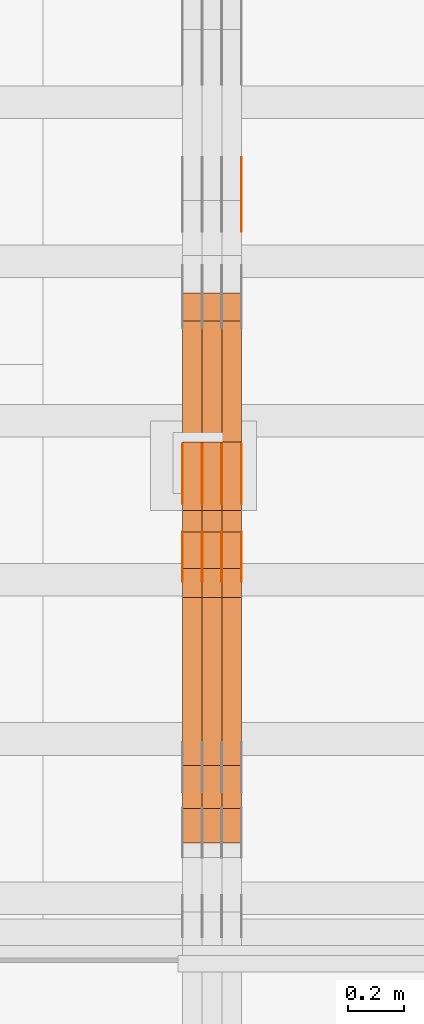
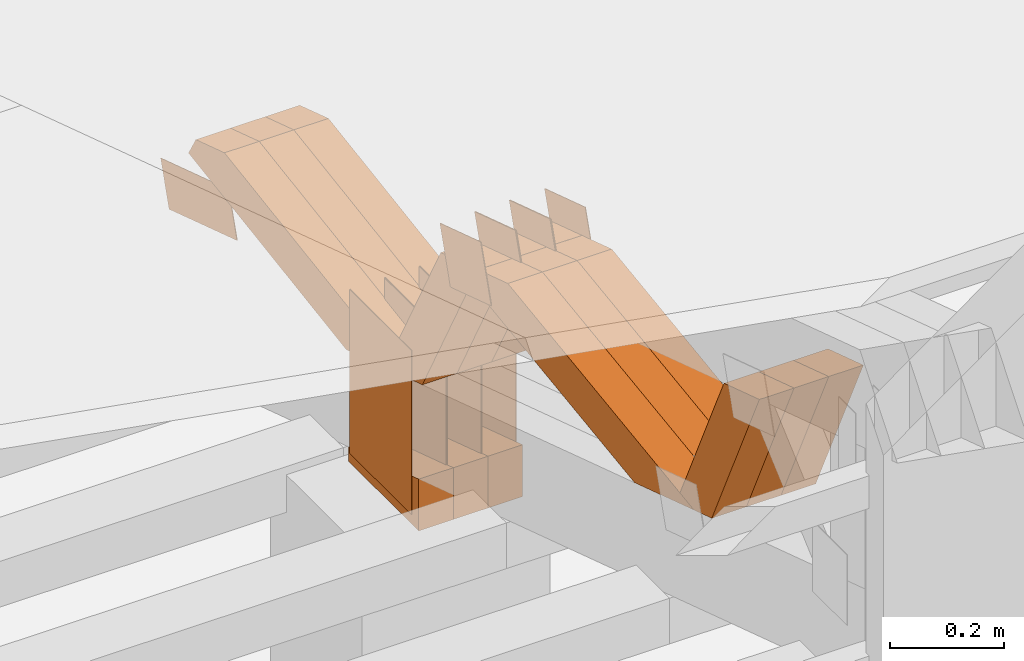
# One storey, part 100 of 385: 28 proxies.
"""IFC2X3 building model written with IfcOpenShell, lengths in millimetres."""

from ifc_helpers import new_model, entity, si_unit, converted_unit, derived_unit, direction, frame, origin, origin_2d_with_axis, place, context, subcontext, project, spatial, polyline, rectangle, outline, extrude, source, transform, mapped, material, type_object, type_shapes, element, save


model = new_model("IFC2X3")

# Units and contexts
model_context = context("Model", 3, precision=0.01, world=origin(), true_north=direction((6.12303176911189e-17, 1.0)))
body_context = subcontext(model_context, "Body", "Model", "MODEL_VIEW")
ifc_project = project(units=[si_unit("LENGTHUNIT", "METRE", prefix="MILLI"), si_unit("AREAUNIT", "SQUARE_METRE"), si_unit("VOLUMEUNIT", "CUBIC_METRE"), converted_unit("PLANEANGLEUNIT", "DEGREE", entity("IfcRatioMeasure", 0.0174532925199433), si_unit("PLANEANGLEUNIT", "RADIAN"), dimensions=[0, 0, 0, 0, 0, 0, 0]), si_unit("MASSUNIT", "GRAM", prefix="KILO"), derived_unit("MASSDENSITYUNIT", [(si_unit("MASSUNIT", "GRAM", prefix="KILO"), 1), (si_unit("LENGTHUNIT", "METRE"), -3)]), si_unit("TIMEUNIT", "SECOND"), si_unit("FREQUENCYUNIT", "HERTZ"), si_unit("THERMODYNAMICTEMPERATUREUNIT", "DEGREE_CELSIUS"), derived_unit("THERMALTRANSMITTANCEUNIT", [(si_unit("MASSUNIT", "GRAM", prefix="KILO"), 1), (si_unit("THERMODYNAMICTEMPERATUREUNIT", "KELVIN"), -1), (si_unit("TIMEUNIT", "SECOND"), -3)]), derived_unit("VOLUMETRICFLOWRATEUNIT", [(si_unit("LENGTHUNIT", "METRE"), 3), (si_unit("TIMEUNIT", "SECOND"), -1)]), si_unit("ELECTRICCURRENTUNIT", "AMPERE"), si_unit("ELECTRICVOLTAGEUNIT", "VOLT"), si_unit("POWERUNIT", "WATT"), si_unit("FORCEUNIT", "NEWTON", prefix="KILO"), si_unit("ILLUMINANCEUNIT", "LUX"), si_unit("LUMINOUSFLUXUNIT", "LUMEN"), si_unit("LUMINOUSINTENSITYUNIT", "CANDELA"), derived_unit("USERDEFINED", [(si_unit("MASSUNIT", "GRAM", prefix="KILO"), -1), (si_unit("LENGTHUNIT", "METRE"), -2), (si_unit("TIMEUNIT", "SECOND"), 3), (si_unit("LUMINOUSFLUXUNIT", "LUMEN"), 1)]), derived_unit("LINEARVELOCITYUNIT", [(si_unit("LENGTHUNIT", "METRE"), 1), (si_unit("TIMEUNIT", "SECOND"), -1)]), si_unit("PRESSUREUNIT", "PASCAL"), derived_unit("USERDEFINED", [(si_unit("LENGTHUNIT", "METRE"), -2), (si_unit("MASSUNIT", "GRAM", prefix="KILO"), 1), (si_unit("TIMEUNIT", "SECOND"), -2)])], contexts=[model_context])

# Site, building, storey
site_placement = place(None, origin())
site = spatial("IfcSite", under=ifc_project, at=site_placement, CompositionType="ELEMENT")
building_placement = place(site_placement, origin())
building = spatial("IfcBuilding", under=site, at=building_placement, CompositionType="ELEMENT")
storey_placement = place(building_placement, origin())
storey = spatial("IfcBuildingStorey", under=building, at=storey_placement, Name="Default", CompositionType="ELEMENT", Elevation=0.0)

# Proxies
ifc_material_1 = material(Name="IfcSurfaceStyle #135830")
building_element_proxy_type_1 = type_object("IfcBuildingElementProxyType", PredefinedType="NOTDEFINED", material=ifc_material_1)
shared_shape_1 = source(origin(), body_context, "Body", "SweptSolid", [
    extrude(outline(polyline([(-125.00031378339, -47.9999612158856), (125.000225258022, -47.9999612158856), (124.999811678525, 47.9999612158856), (-124.999723153156, 47.9999612158856), (-125.00031378339, -47.9999612158856)])), frame((125.000225258022, 48.0000091013474, 0.0), z_axis=(0.0, 0.0, 1.0), x_axis=(-1.0, 0.0, 0.0)), (0.0, 0.0, 1.0), 1.3),
])
type_shapes(building_element_proxy_type_1, [shared_shape_1])
proxy_1_placement = place(building_placement, frame((9386.29999999998, 18456.8597683375, 2657.46691321253), z_axis=(-1.0, 0.0, 0.0), x_axis=(0.0, -0.951056516295124, 0.309016994375039)))
element("IfcBuildingElementProxy", 1, at=proxy_1_placement, inside=storey, type_object=building_element_proxy_type_1, material=ifc_material_1, context=body_context, shape_type="MappedRepresentation", body=[
    mapped(shared_shape_1, transform((0.0, 0.0, 0.0), scale=1.0)),
])
ifc_material_2 = material(Name="IfcSurfaceStyle #133778")
building_element_proxy_type_2 = type_object("IfcBuildingElementProxyType", PredefinedType="NOTDEFINED", material=ifc_material_2)
shared_shape_2 = source(origin(), body_context, "Body", "SweptSolid", [
    extrude(rectangle(XDim=350.0, YDim=215.999999999984, at=origin_2d_with_axis()), frame((175.0, 108.0, 0.0), z_axis=(0.0, 0.0, 1.0), x_axis=(-1.0, 0.0, 0.0)), (0.0, 0.0, 1.0), 1.29999999999999),
])
type_shapes(building_element_proxy_type_2, [shared_shape_2])
proxy_2_placement = place(building_placement, frame((9386.29999999998, 17459.2939453125, 3165.36425781251), z_axis=(-1.0, 0.0, 0.0), x_axis=(0.0, 0.0, -1.0)))
element("IfcBuildingElementProxy", 2, at=proxy_2_placement, inside=storey, type_object=building_element_proxy_type_2, material=ifc_material_2, context=body_context, shape_type="MappedRepresentation", body=[
    mapped(shared_shape_2, transform((0.0, 0.0, 0.0), scale=1.0)),
])
ifc_material_3 = material(Name="IfcSurfaceStyle #133721")
building_element_proxy_type_3 = type_object("IfcBuildingElementProxyType", PredefinedType="NOTDEFINED", material=ifc_material_3)
shared_shape_3 = source(origin(), body_context, "Body", "SweptSolid", [
    extrude(rectangle(XDim=350.0, YDim=215.999999999984, at=origin_2d_with_axis()), frame((175.0, 108.0, 0.0), z_axis=(0.0, 0.0, 1.0), x_axis=(-1.0, 0.0, 0.0)), (0.0, 0.0, 1.0), 1.29999999999999),
])
type_shapes(building_element_proxy_type_3, [shared_shape_3])
proxy_3_placement = place(building_placement, frame((9315.0, 17459.2939453125, 3165.36425781251), z_axis=(-1.0, 0.0, 0.0), x_axis=(0.0, 0.0, -1.0)))
element("IfcBuildingElementProxy", 3, at=proxy_3_placement, inside=storey, type_object=building_element_proxy_type_3, material=ifc_material_3, context=body_context, shape_type="MappedRepresentation", body=[
    mapped(shared_shape_3, transform((0.0, 0.0, 0.0), scale=1.0)),
])
ifc_material_4 = material(Name="IfcSurfaceStyle #133664")
building_element_proxy_type_4 = type_object("IfcBuildingElementProxyType", PredefinedType="NOTDEFINED", material=ifc_material_4)
shared_shape_4 = source(origin(), body_context, "Body", "SweptSolid", [
    extrude(rectangle(XDim=350.0, YDim=215.999999999984, at=origin_2d_with_axis()), frame((175.0, 108.0, 0.0), z_axis=(0.0, 0.0, 1.0), x_axis=(-1.0, 0.0, 0.0)), (0.0, 0.0, 1.0), 1.29999999999999),
])
type_shapes(building_element_proxy_type_4, [shared_shape_4])
proxy_4_placement = place(building_placement, frame((9316.29999999998, 17459.2939453125, 3165.36425781251), z_axis=(-1.0, 0.0, 0.0), x_axis=(0.0, 0.0, -1.0)))
element("IfcBuildingElementProxy", 4, at=proxy_4_placement, inside=storey, type_object=building_element_proxy_type_4, material=ifc_material_4, context=body_context, shape_type="MappedRepresentation", body=[
    mapped(shared_shape_4, transform((0.0, 0.0, 0.0), scale=1.0)),
])
ifc_material_5 = material(Name="IfcSurfaceStyle #133607")
building_element_proxy_type_5 = type_object("IfcBuildingElementProxyType", PredefinedType="NOTDEFINED", material=ifc_material_5)
shared_shape_5 = source(origin(), body_context, "Body", "SweptSolid", [
    extrude(rectangle(XDim=350.0, YDim=215.999999999984, at=origin_2d_with_axis()), frame((175.0, 108.0, 0.0), z_axis=(0.0, 0.0, 1.0), x_axis=(-1.0, 0.0, 0.0)), (0.0, 0.0, 1.0), 1.29999999999998),
])
type_shapes(building_element_proxy_type_5, [shared_shape_5])
proxy_5_placement = place(building_placement, frame((9245.0, 17459.2939453125, 3165.36425781251), z_axis=(-1.0, 0.0, 0.0), x_axis=(0.0, 0.0, -1.0)))
element("IfcBuildingElementProxy", 5, at=proxy_5_placement, inside=storey, type_object=building_element_proxy_type_5, material=ifc_material_5, context=body_context, shape_type="MappedRepresentation", body=[
    mapped(shared_shape_5, transform((0.0, 0.0, 0.0), scale=1.0)),
])
ifc_material_6 = material(Name="IfcSurfaceStyle #133550")
building_element_proxy_type_6 = type_object("IfcBuildingElementProxyType", PredefinedType="NOTDEFINED", material=ifc_material_6)
shared_shape_6 = source(origin(), body_context, "Body", "SweptSolid", [
    extrude(rectangle(XDim=350.0, YDim=215.999999999984, at=origin_2d_with_axis()), frame((175.0, 108.0, 0.0), z_axis=(0.0, 0.0, 1.0), x_axis=(-1.0, 0.0, 0.0)), (0.0, 0.0, 1.0), 1.29999999999998),
])
type_shapes(building_element_proxy_type_6, [shared_shape_6])
proxy_6_placement = place(building_placement, frame((9246.29999999998, 17459.2939453125, 3165.36425781251), z_axis=(-1.0, 0.0, 0.0), x_axis=(0.0, 0.0, -1.0)))
element("IfcBuildingElementProxy", 6, at=proxy_6_placement, inside=storey, type_object=building_element_proxy_type_6, material=ifc_material_6, context=body_context, shape_type="MappedRepresentation", body=[
    mapped(shared_shape_6, transform((0.0, 0.0, 0.0), scale=1.0)),
])
ifc_material_7 = material(Name="IfcSurfaceStyle #133493")
building_element_proxy_type_7 = type_object("IfcBuildingElementProxyType", PredefinedType="NOTDEFINED", material=ifc_material_7)
shared_shape_7 = source(origin(), body_context, "Body", "SweptSolid", [
    extrude(rectangle(XDim=350.0, YDim=215.999999999984, at=origin_2d_with_axis()), frame((175.0, 108.0, 0.0), z_axis=(0.0, 0.0, 1.0), x_axis=(-1.0, 0.0, 0.0)), (0.0, 0.0, 1.0), 1.29999999999998),
])
type_shapes(building_element_proxy_type_7, [shared_shape_7])
proxy_7_placement = place(building_placement, frame((9175.0, 17459.2939453125, 3165.36425781251), z_axis=(-1.0, 0.0, 0.0), x_axis=(0.0, 0.0, -1.0)))
element("IfcBuildingElementProxy", 7, at=proxy_7_placement, inside=storey, type_object=building_element_proxy_type_7, material=ifc_material_7, context=body_context, shape_type="MappedRepresentation", body=[
    mapped(shared_shape_7, transform((0.0, 0.0, 0.0), scale=1.0)),
])
ifc_material_8 = material(Name="IfcSurfaceStyle #130358")
building_element_proxy_type_8 = type_object("IfcBuildingElementProxyType", PredefinedType="NOTDEFINED", material=ifc_material_8)
shared_shape_8 = source(origin(), body_context, "Body", "SweptSolid", [
    extrude(outline(polyline([(-74.9998605591058, -59.9999264677524), (74.999875428623, -59.9999264677524), (74.9998605591068, 59.9999264677524), (-74.9998754286239, 59.9999264677524), (-74.9998605591058, -59.9999264677524)])), frame((75.0002460484325, 60.0000016373508, 0.0), z_axis=(0.0, 0.0, 1.0), x_axis=(-1.0, 0.0, 0.0)), (0.0, 0.0, 1.0), 1.3),
])
type_shapes(building_element_proxy_type_8, [shared_shape_8])
proxy_8_placement = place(building_placement, frame((9386.29999999998, 17107.0599369346, 3383.82825001787), z_axis=(-1.0, 0.0, 0.0), x_axis=(0.0, -0.951056516295154, 0.309016994374948)))
element("IfcBuildingElementProxy", 8, at=proxy_8_placement, inside=storey, type_object=building_element_proxy_type_8, material=ifc_material_8, context=body_context, shape_type="MappedRepresentation", body=[
    mapped(shared_shape_8, transform((0.0, 0.0, 0.0), scale=1.0)),
])
ifc_material_9 = material(Name="IfcSurfaceStyle #130301")
building_element_proxy_type_9 = type_object("IfcBuildingElementProxyType", PredefinedType="NOTDEFINED", material=ifc_material_9)
shared_shape_9 = source(origin(), body_context, "Body", "SweptSolid", [
    extrude(outline(polyline([(-74.9998605591058, -59.9999264677524), (74.999875428623, -59.9999264677524), (74.9998605591068, 59.9999264677524), (-74.9998754286239, 59.9999264677524), (-74.9998605591058, -59.9999264677524)])), frame((75.0002460484325, 60.0000016373508, 0.0), z_axis=(0.0, 0.0, 1.0), x_axis=(-1.0, 0.0, 0.0)), (0.0, 0.0, 1.0), 1.3),
])
type_shapes(building_element_proxy_type_9, [shared_shape_9])
proxy_9_placement = place(building_placement, frame((9315.0, 17107.0599369346, 3383.82825001787), z_axis=(-1.0, 0.0, 0.0), x_axis=(0.0, -0.951056516295154, 0.309016994374948)))
element("IfcBuildingElementProxy", 9, at=proxy_9_placement, inside=storey, type_object=building_element_proxy_type_9, material=ifc_material_9, context=body_context, shape_type="MappedRepresentation", body=[
    mapped(shared_shape_9, transform((0.0, 0.0, 0.0), scale=1.0)),
])
ifc_material_10 = material(Name="IfcSurfaceStyle #130244")
building_element_proxy_type_10 = type_object("IfcBuildingElementProxyType", PredefinedType="NOTDEFINED", material=ifc_material_10)
shared_shape_10 = source(origin(), body_context, "Body", "SweptSolid", [
    extrude(outline(polyline([(-74.9998605591058, -59.9999264677524), (74.999875428623, -59.9999264677524), (74.9998605591068, 59.9999264677524), (-74.9998754286239, 59.9999264677524), (-74.9998605591058, -59.9999264677524)])), frame((75.0002460484325, 60.0000016373508, 0.0), z_axis=(0.0, 0.0, 1.0), x_axis=(-1.0, 0.0, 0.0)), (0.0, 0.0, 1.0), 1.3),
])
type_shapes(building_element_proxy_type_10, [shared_shape_10])
proxy_10_placement = place(building_placement, frame((9316.29999999998, 17107.0599369346, 3383.82825001787), z_axis=(-1.0, 0.0, 0.0), x_axis=(0.0, -0.951056516295154, 0.309016994374948)))
element("IfcBuildingElementProxy", 10, at=proxy_10_placement, inside=storey, type_object=building_element_proxy_type_10, material=ifc_material_10, context=body_context, shape_type="MappedRepresentation", body=[
    mapped(shared_shape_10, transform((0.0, 0.0, 0.0), scale=1.0)),
])
ifc_material_11 = material(Name="IfcSurfaceStyle #130187")
building_element_proxy_type_11 = type_object("IfcBuildingElementProxyType", PredefinedType="NOTDEFINED", material=ifc_material_11)
shared_shape_11 = source(origin(), body_context, "Body", "SweptSolid", [
    extrude(outline(polyline([(-74.9998605591058, -59.9999264677524), (74.999875428623, -59.9999264677524), (74.9998605591068, 59.9999264677524), (-74.9998754286239, 59.9999264677524), (-74.9998605591058, -59.9999264677524)])), frame((75.0002460484325, 60.0000016373508, 0.0), z_axis=(0.0, 0.0, 1.0), x_axis=(-1.0, 0.0, 0.0)), (0.0, 0.0, 1.0), 1.29999999999999),
])
type_shapes(building_element_proxy_type_11, [shared_shape_11])
proxy_11_placement = place(building_placement, frame((9245.0, 17107.0599369346, 3383.82825001787), z_axis=(-1.0, 0.0, 0.0), x_axis=(0.0, -0.951056516295154, 0.309016994374948)))
element("IfcBuildingElementProxy", 11, at=proxy_11_placement, inside=storey, type_object=building_element_proxy_type_11, material=ifc_material_11, context=body_context, shape_type="MappedRepresentation", body=[
    mapped(shared_shape_11, transform((0.0, 0.0, 0.0), scale=1.0)),
])
ifc_material_12 = material(Name="IfcSurfaceStyle #130130")
building_element_proxy_type_12 = type_object("IfcBuildingElementProxyType", PredefinedType="NOTDEFINED", material=ifc_material_12)
shared_shape_12 = source(origin(), body_context, "Body", "SweptSolid", [
    extrude(outline(polyline([(-74.9998605591058, -59.9999264677524), (74.999875428623, -59.9999264677524), (74.9998605591068, 59.9999264677524), (-74.9998754286239, 59.9999264677524), (-74.9998605591058, -59.9999264677524)])), frame((75.0002460484325, 60.0000016373508, 0.0), z_axis=(0.0, 0.0, 1.0), x_axis=(-1.0, 0.0, 0.0)), (0.0, 0.0, 1.0), 1.29999999999999),
])
type_shapes(building_element_proxy_type_12, [shared_shape_12])
proxy_12_placement = place(building_placement, frame((9246.29999999998, 17107.0599369346, 3383.82825001787), z_axis=(-1.0, 0.0, 0.0), x_axis=(0.0, -0.951056516295154, 0.309016994374948)))
element("IfcBuildingElementProxy", 12, at=proxy_12_placement, inside=storey, type_object=building_element_proxy_type_12, material=ifc_material_12, context=body_context, shape_type="MappedRepresentation", body=[
    mapped(shared_shape_12, transform((0.0, 0.0, 0.0), scale=1.0)),
])
ifc_material_13 = material(Name="IfcSurfaceStyle #130073")
building_element_proxy_type_13 = type_object("IfcBuildingElementProxyType", PredefinedType="NOTDEFINED", material=ifc_material_13)
shared_shape_13 = source(origin(), body_context, "Body", "SweptSolid", [
    extrude(outline(polyline([(-74.9998605591058, -59.9999264677524), (74.999875428623, -59.9999264677524), (74.9998605591068, 59.9999264677524), (-74.9998754286239, 59.9999264677524), (-74.9998605591058, -59.9999264677524)])), frame((75.0002460484325, 60.0000016373508, 0.0), z_axis=(0.0, 0.0, 1.0), x_axis=(-1.0, 0.0, 0.0)), (0.0, 0.0, 1.0), 1.29999999999999),
])
type_shapes(building_element_proxy_type_13, [shared_shape_13])
proxy_13_placement = place(building_placement, frame((9175.0, 17107.0599369346, 3383.82825001787), z_axis=(-1.0, 0.0, 0.0), x_axis=(0.0, -0.951056516295154, 0.309016994374948)))
element("IfcBuildingElementProxy", 13, at=proxy_13_placement, inside=storey, type_object=building_element_proxy_type_13, material=ifc_material_13, context=body_context, shape_type="MappedRepresentation", body=[
    mapped(shared_shape_13, transform((0.0, 0.0, 0.0), scale=1.0)),
])
ifc_material_14 = material(Name="IfcSurfaceStyle #122069")
building_element_proxy_type_14 = type_object("IfcBuildingElementProxyType", Name="T1-E1 122067", PredefinedType="NOTDEFINED", material=ifc_material_14)
shared_shape_14 = source(origin(), body_context, "Body", "SweptSolid", [
    extrude(outline(polyline([(4.4675903320374, -122.500000000001), (35.3350219726624, -122.500000000001), (35.3350219726501, 122.500000000001), (-75.1376342773499, 122.500000000001), (4.4675903320374, -122.500000000001)])), frame((35.3350219726624, 122.50000005215, 0.0), z_axis=(0.0, 0.0, 1.0), x_axis=(-1.0, 0.0, 0.0)), (0.0, 0.0, 1.0), 70.0),
])
type_shapes(building_element_proxy_type_14, [shared_shape_14])
proxy_14_placement = place(building_placement, frame((9385.0, 17220.0, 2794.30932617186), z_axis=(-1.0, 0.0, 0.0), x_axis=(0.0, 0.0, 1.0)))
element("IfcBuildingElementProxy", 14, at=proxy_14_placement, inside=storey, type_object=building_element_proxy_type_14, material=ifc_material_14, Name="T1-E1", context=body_context, shape_type="MappedRepresentation", body=[
    mapped(shared_shape_14, transform((0.0, 0.0, 0.0), scale=1.0)),
])
ifc_material_15 = material(Name="IfcSurfaceStyle #122012")
building_element_proxy_type_15 = type_object("IfcBuildingElementProxyType", Name="T1-E1 122010", PredefinedType="NOTDEFINED", material=ifc_material_15)
shared_shape_15 = source(origin(), body_context, "Body", "SweptSolid", [
    extrude(outline(polyline([(4.4675903320374, -122.500000000001), (35.3350219726624, -122.500000000001), (35.3350219726501, 122.500000000001), (-75.1376342773499, 122.500000000001), (4.4675903320374, -122.500000000001)])), frame((35.3350219726624, 122.50000005215, 0.0), z_axis=(0.0, 0.0, 1.0), x_axis=(-1.0, 0.0, 0.0)), (0.0, 0.0, 1.0), 70.0),
])
type_shapes(building_element_proxy_type_15, [shared_shape_15])
proxy_15_placement = place(building_placement, frame((9315.0, 17220.0, 2794.30932617186), z_axis=(-1.0, 0.0, 0.0), x_axis=(0.0, 0.0, 1.0)))
element("IfcBuildingElementProxy", 15, at=proxy_15_placement, inside=storey, type_object=building_element_proxy_type_15, material=ifc_material_15, Name="T1-E1", context=body_context, shape_type="MappedRepresentation", body=[
    mapped(shared_shape_15, transform((0.0, 0.0, 0.0), scale=1.0)),
])
ifc_material_16 = material(Name="IfcSurfaceStyle #121955")
building_element_proxy_type_16 = type_object("IfcBuildingElementProxyType", Name="T1-E1 121953", PredefinedType="NOTDEFINED", material=ifc_material_16)
shared_shape_16 = source(origin(), body_context, "Body", "SweptSolid", [
    extrude(outline(polyline([(4.4675903320374, -122.500000000001), (35.3350219726624, -122.500000000001), (35.3350219726501, 122.500000000001), (-75.1376342773499, 122.500000000001), (4.4675903320374, -122.500000000001)])), frame((35.3350219726624, 122.50000005215, 0.0), z_axis=(0.0, 0.0, 1.0), x_axis=(-1.0, 0.0, 0.0)), (0.0, 0.0, 1.0), 70.0),
])
type_shapes(building_element_proxy_type_16, [shared_shape_16])
proxy_16_placement = place(building_placement, frame((9245.0, 17220.0, 2794.30932617186), z_axis=(-1.0, 0.0, 0.0), x_axis=(0.0, 0.0, 1.0)))
element("IfcBuildingElementProxy", 16, at=proxy_16_placement, inside=storey, type_object=building_element_proxy_type_16, material=ifc_material_16, Name="T1-E1", context=body_context, shape_type="MappedRepresentation", body=[
    mapped(shared_shape_16, transform((0.0, 0.0, 0.0), scale=1.0)),
])
ifc_material_17 = material(Name="IfcSurfaceStyle #121106")
building_element_proxy_type_17 = type_object("IfcBuildingElementProxyType", Name="T1-W44 121104", PredefinedType="NOTDEFINED", material=ifc_material_17)
shared_shape_17 = source(origin(), body_context, "Body", "SweptSolid", [
    extrude(outline(polyline([(-184.551057772692, -47.4997984945814), (177.527112951531, -47.4997984945814), (162.630077773546, -0.000452497529500495), (118.068221667048, 47.5000247433462), (-273.674354619433, 47.5000247433462), (-184.551057772692, -47.4997984945814)])), frame((177.527112951531, 47.5002721629815, 0.0), z_axis=(0.0, 0.0, 1.0), x_axis=(-1.0, 0.0, 0.0)), (0.0, 0.0, 1.0), 70.0),
])
type_shapes(building_element_proxy_type_17, [shared_shape_17])
proxy_17_placement = place(building_placement, frame((9385.0, 16220.4899216004, 3388.98238154171), z_axis=(-1.0, 0.0, 0.0), x_axis=(0.0, -0.425335045192995, 0.905035965766374)))
element("IfcBuildingElementProxy", 17, at=proxy_17_placement, inside=storey, type_object=building_element_proxy_type_17, material=ifc_material_17, Name="T1-W44", context=body_context, shape_type="MappedRepresentation", body=[
    mapped(shared_shape_17, transform((0.0, 0.0, 0.0), scale=1.0)),
])
ifc_material_18 = material(Name="IfcSurfaceStyle #121040")
building_element_proxy_type_18 = type_object("IfcBuildingElementProxyType", Name="T1-W44 121038", PredefinedType="NOTDEFINED", material=ifc_material_18)
shared_shape_18 = source(origin(), body_context, "Body", "SweptSolid", [
    extrude(outline(polyline([(-184.551057772692, -47.4997984945814), (177.527112951531, -47.4997984945814), (162.630077773546, -0.000452497529500495), (118.068221667048, 47.5000247433462), (-273.674354619433, 47.5000247433462), (-184.551057772692, -47.4997984945814)])), frame((177.527112951531, 47.5002721629815, 0.0), z_axis=(0.0, 0.0, 1.0), x_axis=(-1.0, 0.0, 0.0)), (0.0, 0.0, 1.0), 70.0),
])
type_shapes(building_element_proxy_type_18, [shared_shape_18])
proxy_18_placement = place(building_placement, frame((9315.0, 16220.4899216004, 3388.98238154171), z_axis=(-1.0, 0.0, 0.0), x_axis=(0.0, -0.425335045192995, 0.905035965766374)))
element("IfcBuildingElementProxy", 18, at=proxy_18_placement, inside=storey, type_object=building_element_proxy_type_18, material=ifc_material_18, Name="T1-W44", context=body_context, shape_type="MappedRepresentation", body=[
    mapped(shared_shape_18, transform((0.0, 0.0, 0.0), scale=1.0)),
])
ifc_material_19 = material(Name="IfcSurfaceStyle #120974")
building_element_proxy_type_19 = type_object("IfcBuildingElementProxyType", Name="T1-W44 120972", PredefinedType="NOTDEFINED", material=ifc_material_19)
shared_shape_19 = source(origin(), body_context, "Body", "SweptSolid", [
    extrude(outline(polyline([(-184.551057772692, -47.4997984945814), (177.527112951531, -47.4997984945814), (162.630077773546, -0.000452497529500495), (118.068221667048, 47.5000247433462), (-273.674354619433, 47.5000247433462), (-184.551057772692, -47.4997984945814)])), frame((177.527112951531, 47.5002721629815, 0.0), z_axis=(0.0, 0.0, 1.0), x_axis=(-1.0, 0.0, 0.0)), (0.0, 0.0, 1.0), 70.0),
])
type_shapes(building_element_proxy_type_19, [shared_shape_19])
proxy_19_placement = place(building_placement, frame((9245.0, 16220.4899216004, 3388.98238154171), z_axis=(-1.0, 0.0, 0.0), x_axis=(0.0, -0.425335045192995, 0.905035965766374)))
element("IfcBuildingElementProxy", 19, at=proxy_19_placement, inside=storey, type_object=building_element_proxy_type_19, material=ifc_material_19, Name="T1-W44", context=body_context, shape_type="MappedRepresentation", body=[
    mapped(shared_shape_19, transform((0.0, 0.0, 0.0), scale=1.0)),
])
ifc_material_20 = material(Name="IfcSurfaceStyle #120710")
building_element_proxy_type_20 = type_object("IfcBuildingElementProxyType", Name="T1-W8 120708", PredefinedType="NOTDEFINED", material=ifc_material_20)
shared_shape_20 = source(origin(), body_context, "Body", "SweptSolid", [
    extrude(outline(polyline([(-476.725263324644, -47.5001051695965), (180.672765845439, -47.5001051695965), (279.11020091716, -1.03605560390907e-06), (296.793624402619, 47.5001056876243), (-279.851327840575, 47.5001056876243), (-476.725263324644, -47.5001051695965)])), frame((296.793624402619, 47.5001056876243, 0.0), z_axis=(0.0, 0.0, 1.0), x_axis=(-1.0, 0.0, 0.0)), (0.0, 0.0, 1.0), 70.0),
])
type_shapes(building_element_proxy_type_20, [shared_shape_20])
proxy_20_placement = place(building_placement, frame((9385.0, 17036.40625, 3432.97192382813), z_axis=(-1.0, 0.0, 0.0), x_axis=(0.0, -0.990844046556832, -0.135011389900564)))
element("IfcBuildingElementProxy", 20, at=proxy_20_placement, inside=storey, type_object=building_element_proxy_type_20, material=ifc_material_20, Name="T1-W8", context=body_context, shape_type="MappedRepresentation", body=[
    mapped(shared_shape_20, transform((0.0, 0.0, 0.0), scale=1.0)),
])
ifc_material_21 = material(Name="IfcSurfaceStyle #120644")
building_element_proxy_type_21 = type_object("IfcBuildingElementProxyType", Name="T1-W8 120642", PredefinedType="NOTDEFINED", material=ifc_material_21)
shared_shape_21 = source(origin(), body_context, "Body", "SweptSolid", [
    extrude(outline(polyline([(-476.725263324644, -47.5001051695965), (180.672765845439, -47.5001051695965), (279.11020091716, -1.03605560390907e-06), (296.793624402619, 47.5001056876243), (-279.851327840575, 47.5001056876243), (-476.725263324644, -47.5001051695965)])), frame((296.793624402619, 47.5001056876243, 0.0), z_axis=(0.0, 0.0, 1.0), x_axis=(-1.0, 0.0, 0.0)), (0.0, 0.0, 1.0), 70.0),
])
type_shapes(building_element_proxy_type_21, [shared_shape_21])
proxy_21_placement = place(building_placement, frame((9315.0, 17036.40625, 3432.97192382813), z_axis=(-1.0, 0.0, 0.0), x_axis=(0.0, -0.990844046556832, -0.135011389900564)))
element("IfcBuildingElementProxy", 21, at=proxy_21_placement, inside=storey, type_object=building_element_proxy_type_21, material=ifc_material_21, Name="T1-W8", context=body_context, shape_type="MappedRepresentation", body=[
    mapped(shared_shape_21, transform((0.0, 0.0, 0.0), scale=1.0)),
])
ifc_material_22 = material(Name="IfcSurfaceStyle #120578")
building_element_proxy_type_22 = type_object("IfcBuildingElementProxyType", Name="T1-W8 120576", PredefinedType="NOTDEFINED", material=ifc_material_22)
shared_shape_22 = source(origin(), body_context, "Body", "SweptSolid", [
    extrude(outline(polyline([(-476.725263324644, -47.5001051695965), (180.672765845439, -47.5001051695965), (279.11020091716, -1.03605560390907e-06), (296.793624402619, 47.5001056876243), (-279.851327840575, 47.5001056876243), (-476.725263324644, -47.5001051695965)])), frame((296.793624402619, 47.5001056876243, 0.0), z_axis=(0.0, 0.0, 1.0), x_axis=(-1.0, 0.0, 0.0)), (0.0, 0.0, 1.0), 70.0),
])
type_shapes(building_element_proxy_type_22, [shared_shape_22])
proxy_22_placement = place(building_placement, frame((9245.0, 17036.40625, 3432.97192382813), z_axis=(-1.0, 0.0, 0.0), x_axis=(0.0, -0.990844046556832, -0.135011389900564)))
element("IfcBuildingElementProxy", 22, at=proxy_22_placement, inside=storey, type_object=building_element_proxy_type_22, material=ifc_material_22, Name="T1-W8", context=body_context, shape_type="MappedRepresentation", body=[
    mapped(shared_shape_22, transform((0.0, 0.0, 0.0), scale=1.0)),
])
ifc_material_23 = material(Name="IfcSurfaceStyle #120314")
building_element_proxy_type_23 = type_object("IfcBuildingElementProxyType", Name="T1-W39 120312", PredefinedType="NOTDEFINED", material=ifc_material_23)
shared_shape_23 = source(origin(), body_context, "Body", "SweptSolid", [
    extrude(outline(polyline([(-191.519946663886, -47.499928106579), (188.32936223763, -47.499928106579), (171.597440144109, 0.000249483340993841), (122.102882529753, 47.4998033649085), (-290.509738247605, 47.4998033649085), (-191.519946663886, -47.499928106579)])), frame((188.329593252001, 47.499957247623, 0.0), z_axis=(0.0, 0.0, 1.0), x_axis=(-1.0, 0.0, 0.0)), (0.0, 0.0, 1.0), 70.0),
])
type_shapes(building_element_proxy_type_23, [shared_shape_23])
proxy_23_placement = place(building_placement, frame((9385.0, 17238.5876916597, 3055.56121424762), z_axis=(-1.0, 0.0, 0.0), x_axis=(0.0, -0.472216932390777, 0.881482370080902)))
element("IfcBuildingElementProxy", 23, at=proxy_23_placement, inside=storey, type_object=building_element_proxy_type_23, material=ifc_material_23, Name="T1-W39", context=body_context, shape_type="MappedRepresentation", body=[
    mapped(shared_shape_23, transform((0.0, 0.0, 0.0), scale=1.0)),
])
ifc_material_24 = material(Name="IfcSurfaceStyle #120248")
building_element_proxy_type_24 = type_object("IfcBuildingElementProxyType", Name="T1-W39 120246", PredefinedType="NOTDEFINED", material=ifc_material_24)
shared_shape_24 = source(origin(), body_context, "Body", "SweptSolid", [
    extrude(outline(polyline([(-191.519946663886, -47.499928106579), (188.32936223763, -47.499928106579), (171.597440144109, 0.000249483340993841), (122.102882529753, 47.4998033649085), (-290.509738247605, 47.4998033649085), (-191.519946663886, -47.499928106579)])), frame((188.329593252001, 47.499957247623, 0.0), z_axis=(0.0, 0.0, 1.0), x_axis=(-1.0, 0.0, 0.0)), (0.0, 0.0, 1.0), 70.0),
])
type_shapes(building_element_proxy_type_24, [shared_shape_24])
proxy_24_placement = place(building_placement, frame((9315.0, 17238.5876916597, 3055.56121424762), z_axis=(-1.0, 0.0, 0.0), x_axis=(0.0, -0.472216932390777, 0.881482370080902)))
element("IfcBuildingElementProxy", 24, at=proxy_24_placement, inside=storey, type_object=building_element_proxy_type_24, material=ifc_material_24, Name="T1-W39", context=body_context, shape_type="MappedRepresentation", body=[
    mapped(shared_shape_24, transform((0.0, 0.0, 0.0), scale=1.0)),
])
ifc_material_25 = material(Name="IfcSurfaceStyle #120182")
building_element_proxy_type_25 = type_object("IfcBuildingElementProxyType", Name="T1-W39 120180", PredefinedType="NOTDEFINED", material=ifc_material_25)
shared_shape_25 = source(origin(), body_context, "Body", "SweptSolid", [
    extrude(outline(polyline([(-191.519946663886, -47.499928106579), (188.32936223763, -47.499928106579), (171.597440144109, 0.000249483340993841), (122.102882529753, 47.4998033649085), (-290.509738247605, 47.4998033649085), (-191.519946663886, -47.499928106579)])), frame((188.329593252001, 47.499957247623, 0.0), z_axis=(0.0, 0.0, 1.0), x_axis=(-1.0, 0.0, 0.0)), (0.0, 0.0, 1.0), 70.0),
])
type_shapes(building_element_proxy_type_25, [shared_shape_25])
proxy_25_placement = place(building_placement, frame((9245.0, 17238.5876916597, 3055.56121424762), z_axis=(-1.0, 0.0, 0.0), x_axis=(0.0, -0.472216932390777, 0.881482370080902)))
element("IfcBuildingElementProxy", 25, at=proxy_25_placement, inside=storey, type_object=building_element_proxy_type_25, material=ifc_material_25, Name="T1-W39", context=body_context, shape_type="MappedRepresentation", body=[
    mapped(shared_shape_25, transform((0.0, 0.0, 0.0), scale=1.0)),
])
ifc_material_26 = material(Name="IfcSurfaceStyle #119918")
building_element_proxy_type_26 = type_object("IfcBuildingElementProxyType", Name="T1-W10 119916", PredefinedType="NOTDEFINED", material=ifc_material_26)
shared_shape_26 = source(origin(), body_context, "Body", "SweptSolid", [
    extrude(outline(polyline([(-459.546036710757, -47.5000436364511), (174.689450869018, -47.5000436364511), (268.831081103959, 0.00011114562912502), (287.286350706789, 47.4999880636365), (-271.260845969009, 47.4999880636366), (-459.546036710757, -47.5000436364511)])), frame((287.286768781132, 47.5001637448091, 0.0), z_axis=(0.0, 0.0, 1.0), x_axis=(-1.0, 0.0, 0.0)), (0.0, 0.0, 1.0), 70.0),
])
type_shapes(building_element_proxy_type_26, [shared_shape_26])
proxy_26_placement = place(building_placement, frame((9385.0, 18025.1410649788, 3112.76453857986), z_axis=(-1.0, 0.0, 0.0), x_axis=(0.0, -0.988299196256916, -0.152527698068035)))
element("IfcBuildingElementProxy", 26, at=proxy_26_placement, inside=storey, type_object=building_element_proxy_type_26, material=ifc_material_26, Name="T1-W10", context=body_context, shape_type="MappedRepresentation", body=[
    mapped(shared_shape_26, transform((0.0, 0.0, 0.0), scale=1.0)),
])
ifc_material_27 = material(Name="IfcSurfaceStyle #119852")
building_element_proxy_type_27 = type_object("IfcBuildingElementProxyType", Name="T1-W10 119850", PredefinedType="NOTDEFINED", material=ifc_material_27)
shared_shape_27 = source(origin(), body_context, "Body", "SweptSolid", [
    extrude(outline(polyline([(-459.546036710757, -47.5000436364511), (174.689450869018, -47.5000436364511), (268.831081103959, 0.00011114562912502), (287.286350706789, 47.4999880636365), (-271.260845969009, 47.4999880636366), (-459.546036710757, -47.5000436364511)])), frame((287.286768781132, 47.5001637448091, 0.0), z_axis=(0.0, 0.0, 1.0), x_axis=(-1.0, 0.0, 0.0)), (0.0, 0.0, 1.0), 70.0),
])
type_shapes(building_element_proxy_type_27, [shared_shape_27])
proxy_27_placement = place(building_placement, frame((9315.0, 18025.1410649788, 3112.76453857986), z_axis=(-1.0, 0.0, 0.0), x_axis=(0.0, -0.988299196256916, -0.152527698068035)))
element("IfcBuildingElementProxy", 27, at=proxy_27_placement, inside=storey, type_object=building_element_proxy_type_27, material=ifc_material_27, Name="T1-W10", context=body_context, shape_type="MappedRepresentation", body=[
    mapped(shared_shape_27, transform((0.0, 0.0, 0.0), scale=1.0)),
])
ifc_material_28 = material(Name="IfcSurfaceStyle #119786")
building_element_proxy_type_28 = type_object("IfcBuildingElementProxyType", Name="T1-W10 119784", PredefinedType="NOTDEFINED", material=ifc_material_28)
shared_shape_28 = source(origin(), body_context, "Body", "SweptSolid", [
    extrude(outline(polyline([(-459.546036710757, -47.5000436364511), (174.689450869018, -47.5000436364511), (268.831081103959, 0.00011114562912502), (287.286350706789, 47.4999880636365), (-271.260845969009, 47.4999880636366), (-459.546036710757, -47.5000436364511)])), frame((287.286768781132, 47.5001637448091, 0.0), z_axis=(0.0, 0.0, 1.0), x_axis=(-1.0, 0.0, 0.0)), (0.0, 0.0, 1.0), 70.0),
])
type_shapes(building_element_proxy_type_28, [shared_shape_28])
proxy_28_placement = place(building_placement, frame((9245.0, 18025.1410649788, 3112.76453857986), z_axis=(-1.0, 0.0, 0.0), x_axis=(0.0, -0.988299196256916, -0.152527698068035)))
element("IfcBuildingElementProxy", 28, at=proxy_28_placement, inside=storey, type_object=building_element_proxy_type_28, material=ifc_material_28, Name="T1-W10", context=body_context, shape_type="MappedRepresentation", body=[
    mapped(shared_shape_28, transform((0.0, 0.0, 0.0), scale=1.0)),
])

save(model, "model.ifc")
